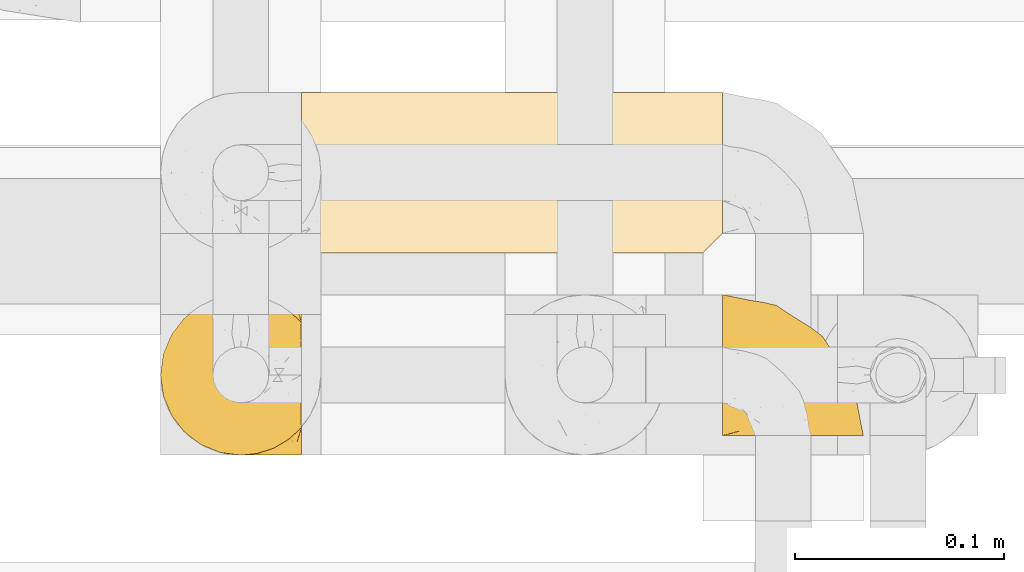
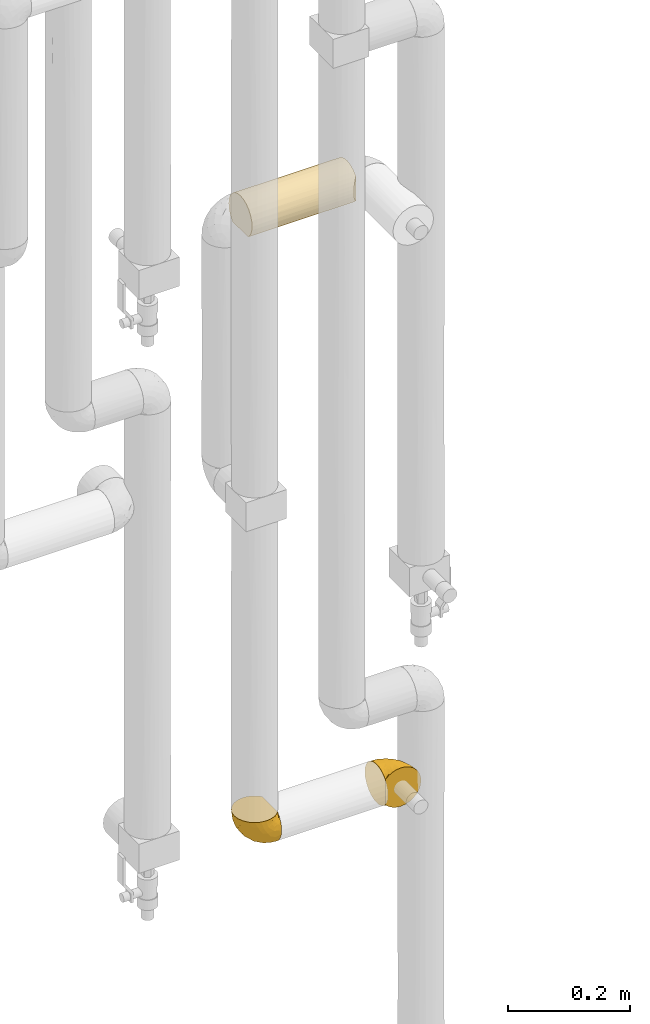
# One storey, part 282 of 827: 3 coverings.
"""IFC2X3 building model written with IfcOpenShell, lengths in millimetres."""

from ifc_helpers import new_model, entity, si_unit, converted_unit, derived_unit, direction, frame, origin, place, context, subcontext, project, spatial, faceted_brep, element, save


model = new_model("IFC2X3")

# Units and contexts
model_context = context("Model", 3, precision=0.01, world=origin(), true_north=direction((6.12303176911189e-17, 1.0)))
body_context = subcontext(model_context, "Body", "Model", "MODEL_VIEW")
ifc_project = project(units=[si_unit("LENGTHUNIT", "METRE", prefix="MILLI"), si_unit("AREAUNIT", "SQUARE_METRE"), si_unit("VOLUMEUNIT", "CUBIC_METRE"), converted_unit("PLANEANGLEUNIT", "DEGREE", entity("IfcRatioMeasure", 0.0174532925199433), si_unit("PLANEANGLEUNIT", "RADIAN"), dimensions=[0, 0, 0, 0, 0, 0, 0]), si_unit("MASSUNIT", "GRAM", prefix="KILO"), derived_unit("MASSDENSITYUNIT", [(si_unit("MASSUNIT", "GRAM", prefix="KILO"), 1), (si_unit("LENGTHUNIT", "METRE"), -3)]), derived_unit("MOMENTOFINERTIAUNIT", [(si_unit("LENGTHUNIT", "METRE"), 4)]), si_unit("TIMEUNIT", "SECOND"), si_unit("FREQUENCYUNIT", "HERTZ"), si_unit("THERMODYNAMICTEMPERATUREUNIT", "DEGREE_CELSIUS"), derived_unit("THERMALTRANSMITTANCEUNIT", [(si_unit("MASSUNIT", "GRAM", prefix="KILO"), 1), (si_unit("THERMODYNAMICTEMPERATUREUNIT", "KELVIN"), -1), (si_unit("TIMEUNIT", "SECOND"), -3)]), derived_unit("VOLUMETRICFLOWRATEUNIT", [(si_unit("LENGTHUNIT", "METRE"), 3), (si_unit("TIMEUNIT", "SECOND"), -1)]), derived_unit("MASSFLOWRATEUNIT", [(si_unit("MASSUNIT", "GRAM", prefix="KILO"), 1), (si_unit("TIMEUNIT", "SECOND"), -1)]), derived_unit("ROTATIONALFREQUENCYUNIT", [(si_unit("TIMEUNIT", "SECOND"), -1)]), si_unit("ELECTRICCURRENTUNIT", "AMPERE"), si_unit("ELECTRICVOLTAGEUNIT", "VOLT"), si_unit("POWERUNIT", "WATT"), si_unit("FORCEUNIT", "NEWTON", prefix="KILO"), si_unit("ILLUMINANCEUNIT", "LUX"), si_unit("LUMINOUSFLUXUNIT", "LUMEN"), si_unit("LUMINOUSINTENSITYUNIT", "CANDELA"), derived_unit("USERDEFINED", [(si_unit("MASSUNIT", "GRAM", prefix="KILO"), -1), (si_unit("LENGTHUNIT", "METRE"), -2), (si_unit("TIMEUNIT", "SECOND"), 3), (si_unit("LUMINOUSFLUXUNIT", "LUMEN"), 1)]), derived_unit("LINEARVELOCITYUNIT", [(si_unit("LENGTHUNIT", "METRE"), 1), (si_unit("TIMEUNIT", "SECOND"), -1)]), si_unit("PRESSUREUNIT", "PASCAL"), derived_unit("USERDEFINED", [(si_unit("LENGTHUNIT", "METRE"), -2), (si_unit("MASSUNIT", "GRAM", prefix="KILO"), 1), (si_unit("TIMEUNIT", "SECOND"), -2)]), derived_unit("LINEARFORCEUNIT", [(si_unit("MASSUNIT", "GRAM", prefix="KILO"), 1), (si_unit("LENGTHUNIT", "METRE"), 1), (si_unit("TIMEUNIT", "SECOND"), -2), (si_unit("LENGTHUNIT", "METRE"), -1)]), derived_unit("PLANARFORCEUNIT", [(si_unit("MASSUNIT", "GRAM", prefix="KILO"), 1), (si_unit("LENGTHUNIT", "METRE"), 1), (si_unit("TIMEUNIT", "SECOND"), -2), (si_unit("LENGTHUNIT", "METRE"), -2)])], contexts=[model_context])

# Site, building, storey
site_placement = place(None, origin())
site = spatial("IfcSite", under=ifc_project, at=site_placement, CompositionType="ELEMENT")
building_placement = place(site_placement, origin())
building = spatial("IfcBuilding", under=site, at=building_placement, CompositionType="ELEMENT")
storey_placement = place(building_placement, frame((0.0, 0.0, 28200.0)))
storey = spatial("IfcBuildingStorey", under=building, at=storey_placement, Name="08", CompositionType="ELEMENT", Elevation=28200.0)

# Coverings
covering_1_placement = place(storey_placement, frame((34787.8, 14884.87, 1019.95)))
element("IfcCovering", 1, at=covering_1_placement, inside=storey, Name=":ADSK_", ObjectType=":ADSK_", PredefinedType="INSULATION", context=body_context, shape_type="Brep", body=[
    faceted_brep([(69.15, 65.47, 68.89), (69.15, 63.27, 68.89), (69.15, 61.53, 68.89), (69.15, 59.57, 68.89), (69.15, 57.6, 68.89), (69.15, 55.63, 68.89), (69.15, 53.67, 68.89), (69.15, 51.7, 68.89), (69.15, 49.73, 68.89), (69.15, 47.54, 68.89), (69.15, 45.34, 68.89), (69.15, 43.15, 68.89), (69.15, 40.96, 68.89), (69.15, 38.76, 68.89), (69.15, 36.57, 68.89), (69.15, 34.37, 68.89), (69.15, 32.18, 68.89), (69.15, 29.98, 68.89), (69.15, 27.79, 68.89), (69.15, 25.6, 68.89), (69.15, 23.4, 68.89), (69.15, 21.21, 68.89), (69.15, 19.01, 68.89), (69.15, 16.82, 68.89), (69.15, 14.62, 68.89), (69.15, 9.12, 62.89), (69.15, 5.0, 55.86), (69.15, 2.46, 48.13), (69.15, 1.6, 40.05), (69.15, 2.56, 31.49), (69.15, 5.41, 23.36), (69.15, 9.99, 16.07), (69.15, 16.08, 9.98), (69.15, 23.37, 5.4), (69.15, 31.49, 2.56), (69.15, 40.05, 1.6), (69.15, 48.61, 2.56), (69.15, 56.73, 5.41), (69.15, 64.02, 9.99), (69.15, 70.11, 16.08), (69.15, 74.69, 23.37), (69.15, 77.53, 31.49), (69.15, 78.5, 40.05), (69.15, 77.63, 48.15), (69.15, 75.08, 55.88), (69.15, 70.97, 62.9), (68.89, 65.47, 69.15), (62.89, 70.97, 69.15), (55.87, 75.09, 69.15), (48.14, 77.63, 69.15), (40.05, 78.5, 69.15), (30.09, 77.19, 69.15), (20.82, 73.34, 69.15), (12.86, 67.23, 69.15), (6.75, 59.27, 69.15), (2.91, 50.0, 69.15), (1.6, 40.05, 69.15), (2.91, 30.09, 69.15), (6.75, 20.82, 69.15), (12.86, 12.86, 69.15), (20.82, 6.75, 69.15), (30.09, 2.91, 69.15), (40.05, 1.6, 69.15), (48.14, 2.46, 69.15), (55.87, 5.0, 69.15), (62.89, 9.12, 69.15), (68.89, 14.62, 69.15), (68.89, 16.82, 69.15), (68.89, 17.8, 69.15), (68.89, 19.39, 69.15), (68.89, 20.98, 69.15), (68.89, 22.57, 69.15), (68.89, 24.16, 69.15), (68.89, 25.75, 69.15), (68.89, 27.33, 69.15), (68.89, 28.92, 69.15), (68.89, 30.51, 69.15), (68.89, 32.1, 69.15), (68.89, 33.69, 69.15), (68.89, 35.28, 69.15), (68.89, 36.87, 69.15), (68.89, 38.46, 69.15), (68.89, 40.05, 69.15), (68.89, 41.63, 69.15), (68.89, 43.22, 69.15), (68.89, 44.81, 69.15), (68.89, 46.4, 69.15), (68.89, 47.99, 69.15), (68.89, 49.58, 69.15), (68.89, 51.17, 69.15), (68.89, 52.76, 69.15), (68.89, 54.72, 69.15), (68.89, 56.69, 69.15), (68.89, 58.88, 69.15), (68.89, 61.08, 69.15), (68.89, 63.27, 69.15), (68.97, 37.77, 68.96), (68.96, 36.07, 68.97), (68.97, 32.96, 68.97), (68.97, 31.36, 68.97), (68.98, 56.52, 68.95), (68.97, 54.96, 68.96), (68.96, 18.75, 68.98), (68.96, 58.07, 68.97), (68.96, 50.37, 68.97), (68.96, 23.36, 68.98), (68.96, 24.95, 68.97), (68.96, 42.43, 68.97), (69.0, 15.97, 68.94), (68.96, 51.96, 68.98), (68.96, 53.47, 68.98), (68.97, 48.63, 68.96), (68.96, 63.93, 68.97), (68.96, 40.93, 68.98), (68.96, 29.72, 68.98), (68.97, 62.4, 68.97), (68.97, 60.92, 68.96), (68.97, 17.31, 68.97), (68.96, 21.74, 68.97), (68.96, 34.56, 68.98), (68.97, 20.18, 68.96), (68.97, 14.62, 68.97), (69.02, 14.62, 68.94), (69.08, 14.62, 68.92), (68.97, 65.47, 68.97), (68.94, 65.47, 69.02), (68.92, 65.47, 69.08), (68.96, 59.5, 68.98), (68.96, 47.1, 68.97), (68.95, 45.61, 68.98), (68.96, 28.18, 68.97), (68.92, 14.62, 69.08), (68.94, 14.62, 69.02), (68.98, 26.61, 68.96), (69.08, 65.47, 68.92), (69.02, 65.47, 68.94), (68.96, 39.32, 68.97), (68.97, 44.12, 68.96), (61.33, 72.26, 67.02), (53.1, 76.57, 63.33), (63.33, 71.77, 64.61), (49.27, 78.5, 49.27), (55.53, 77.9, 51.4), (54.6, 78.5, 43.94), (41.99, 78.5, 61.87), (57.07, 75.52, 61.54), (57.95, 76.13, 57.95), (51.56, 77.81, 56.12), (61.7, 72.4, 65.41), (63.33, 76.56, 53.1), (65.0, 71.77, 63.04), (67.02, 72.25, 61.33), (61.87, 78.5, 41.99), (43.94, 78.5, 54.6), (61.21, 75.75, 56.6), (63.4, 78.5, 41.58), (26.0, 75.57, 61.54), (58.71, 76.34, 28.67), (33.48, 77.64, 58.75), (14.17, 63.45, 46.12), (18.43, 70.55, 55.56), (24.87, 71.02, 42.09), (45.01, 66.15, 17.15), (44.4, 60.51, 12.68), (35.53, 63.72, 20.17), (28.67, 75.57, 52.38), (49.25, 72.61, 23.76), (48.22, 76.83, 34.7), (59.72, 72.61, 20.5), (55.1, 67.24, 14.64), (5.25, 47.19, 49.4), (6.75, 54.76, 52.34), (10.47, 63.45, 58.67), (52.82, 52.75, 5.82), (16.81, 53.89, 30.64), (17.38, 46.73, 26.66), (10.56, 48.67, 37.53), (11.2, 55.34, 41.11), (21.38, 40.05, 21.38), (33.11, 50.46, 13.72), (43.3, 40.05, 6.74), (32.34, 40.05, 14.06), (44.72, 77.74, 41.77), (36.52, 77.66, 51.58), (34.15, 57.43, 16.28), (55.54, 40.05, 4.3), (57.42, 60.51, 8.62), (25.49, 60.1, 25.26), (23.96, 51.88, 21.47), (34.84, 72.59, 33.37), (36.87, 76.05, 41.35), (4.3, 40.05, 55.54), (20.65, 63.95, 35.17), (29.66, 67.24, 29.04), (39.6, 69.62, 24.34), (42.55, 73.6, 29.33), (6.74, 40.05, 43.3), (14.06, 40.05, 32.34), (5.28, 32.72, 49.41), (63.4, 1.6, 41.58), (58.71, 3.75, 28.66), (33.13, 29.63, 13.7), (18.52, 27.18, 27.85), (52.83, 27.35, 5.82), (44.4, 19.59, 12.67), (42.69, 12.86, 19.45), (55.1, 12.86, 14.63), (49.26, 7.49, 23.75), (20.72, 9.54, 48.85), (11.46, 16.64, 54.13), (17.69, 17.48, 37.84), (35.35, 2.33, 55.15), (43.94, 1.6, 54.6), (41.99, 1.6, 61.87), (29.34, 8.17, 37.91), (30.26, 4.3, 50.18), (4.93, 26.94, 57.58), (29.72, 20.75, 20.83), (17.46, 9.54, 59.91), (26.84, 4.52, 57.75), (59.73, 7.49, 20.49), (61.87, 1.6, 41.99), (54.6, 1.6, 43.94), (57.43, 19.59, 8.61), (48.2, 3.27, 34.7), (43.06, 2.45, 42.64), (49.27, 1.6, 49.27), (10.94, 31.21, 36.94), (8.92, 25.33, 45.72), (33.44, 2.29, 62.29), (29.67, 12.86, 29.01), (38.5, 6.89, 31.47), (39.06, 2.23, 49.29), (23.35, 12.43, 37.18), (34.97, 4.1, 43.45), (53.1, 3.53, 63.33), (59.68, 6.88, 67.23), (62.19, 8.16, 66.07), (64.11, 9.02, 65.22), (57.97, 5.0, 61.99), (57.95, 3.96, 57.95), (63.33, 3.52, 53.09), (51.77, 2.4, 56.84), (67.02, 7.83, 61.33), (64.98, 8.32, 63.06), (55.53, 2.19, 51.41), (61.22, 4.34, 56.61)], [[[0, 1, 2, 3, 4, 5, 6, 7, 8, 9, 10, 11, 12, 13, 14, 15, 16, 17, 18, 19, 20, 21, 22, 23, 24, 25, 26, 27, 28, 29, 30, 31, 32, 33, 34, 35, 36, 37, 38, 39, 40, 41, 42, 43, 44, 45]], [[46, 47, 48, 49, 50, 51, 52, 53, 54, 55, 56, 57, 58, 59, 60, 61, 62, 63, 64, 65, 66, 67, 68, 69, 70, 71, 72, 73, 74, 75, 76, 77, 78, 79, 80, 81, 82, 83, 84, 85, 86, 87, 88, 89, 90, 91, 92, 93, 94, 95]], [[96, 97, 14]], [[98, 77, 99]], [[100, 101, 5]], [[69, 68, 102]], [[4, 3, 103]], [[8, 7, 104]], [[4, 103, 100]], [[72, 105, 106]], [[84, 83, 107]], [[89, 88, 104]], [[108, 67, 66]], [[109, 110, 90]], [[111, 9, 8]], [[112, 1, 0]], [[82, 113, 83]], [[109, 7, 6]], [[114, 76, 75]], [[105, 20, 106]], [[104, 111, 8]], [[2, 115, 116]], [[97, 96, 80]], [[67, 108, 117]], [[105, 71, 118]], [[15, 97, 119]], [[102, 120, 69]], [[108, 121, 122, 123, 24]], [[112, 95, 115]], [[1, 115, 2]], [[94, 116, 115]], [[117, 68, 67]], [[22, 117, 23]], [[112, 124, 125, 126, 46]], [[1, 112, 115]], [[70, 120, 118]], [[23, 117, 108]], [[120, 22, 21]], [[120, 21, 118]], [[120, 70, 69]], [[116, 94, 127]], [[128, 86, 129]], [[117, 22, 102]], [[74, 130, 75]], [[99, 17, 16]], [[115, 95, 94]], [[23, 108, 24]], [[108, 66, 131, 132, 121]], [[105, 72, 71]], [[118, 21, 20]], [[71, 70, 118]], [[19, 106, 20]], [[20, 105, 118]], [[19, 133, 106]], [[74, 73, 133]], [[106, 133, 73]], [[99, 114, 17]], [[133, 19, 18]], [[73, 72, 106]], [[95, 112, 46]], [[112, 0, 134, 135, 124]], [[130, 114, 75]], [[99, 76, 114]], [[114, 130, 17]], [[18, 17, 130]], [[78, 77, 98]], [[98, 119, 78]], [[130, 133, 18]], [[133, 130, 74]], [[79, 97, 80]], [[98, 99, 16]], [[98, 16, 15]], [[77, 76, 99]], [[97, 79, 119]], [[136, 96, 13]], [[14, 97, 15]], [[136, 13, 12]], [[81, 80, 96]], [[13, 96, 14]], [[15, 119, 98]], [[119, 79, 78]], [[96, 136, 81]], [[82, 81, 136]], [[113, 107, 83]], [[84, 107, 137]], [[107, 11, 137]], [[113, 12, 107]], [[11, 107, 12]], [[85, 84, 137]], [[137, 11, 10]], [[113, 136, 12]], [[136, 113, 82]], [[109, 89, 104]], [[86, 85, 129]], [[89, 109, 90]], [[111, 87, 128]], [[10, 129, 137]], [[88, 111, 104]], [[9, 111, 128]], [[6, 110, 109]], [[7, 109, 104]], [[110, 91, 90]], [[100, 92, 101]], [[110, 6, 101]], [[91, 110, 101]], [[116, 3, 2]], [[111, 88, 87]], [[127, 103, 3]], [[9, 128, 10]], [[86, 128, 87]], [[128, 129, 10]], [[137, 129, 85]], [[120, 102, 22]], [[117, 102, 68]], [[91, 101, 92]], [[5, 101, 6]], [[93, 92, 103]], [[100, 5, 4]], [[100, 103, 92]], [[127, 93, 103]], [[93, 127, 94]], [[116, 127, 3]], [[126, 138, 47]], [[48, 138, 139]], [[140, 125, 124]], [[141, 142, 143]], [[144, 49, 139]], [[145, 140, 146]], [[48, 139, 49]], [[139, 145, 147]], [[144, 50, 49]], [[126, 125, 148]], [[44, 43, 149]], [[150, 146, 140]], [[148, 140, 145]], [[151, 150, 135]], [[151, 44, 149]], [[0, 45, 134]], [[43, 152, 149]], [[124, 150, 140]], [[141, 147, 142]], [[44, 151, 45]], [[45, 151, 134]], [[47, 46, 126]], [[139, 153, 144]], [[138, 48, 47]], [[125, 140, 148]], [[135, 134, 151]], [[146, 154, 142]], [[145, 146, 147]], [[148, 139, 138]], [[147, 141, 153]], [[147, 146, 142]], [[139, 147, 153]], [[139, 148, 145]], [[148, 138, 126]], [[154, 146, 150]], [[149, 143, 142]], [[151, 154, 150]], [[149, 142, 154]], [[43, 42, 155, 152]], [[152, 143, 149]], [[151, 149, 154]], [[150, 124, 135]], [[51, 156, 52]], [[155, 41, 157]], [[50, 144, 158]], [[159, 160, 161]], [[162, 163, 164]], [[158, 165, 156]], [[157, 166, 167]], [[166, 168, 169]], [[170, 55, 171]], [[161, 160, 165]], [[172, 54, 53]], [[160, 53, 52]], [[173, 37, 36]], [[54, 172, 171]], [[174, 175, 176]], [[170, 177, 176]], [[167, 143, 157]], [[178, 179, 180, 181]], [[157, 41, 40]], [[141, 182, 183]], [[160, 52, 156]], [[173, 179, 184]], [[38, 169, 39]], [[173, 36, 185]], [[155, 42, 41]], [[38, 37, 186]], [[162, 169, 163]], [[187, 184, 188]], [[180, 173, 185]], [[40, 168, 157]], [[54, 171, 55]], [[186, 173, 163]], [[157, 143, 152, 155]], [[189, 161, 190]], [[179, 173, 180]], [[39, 168, 40]], [[186, 169, 38]], [[187, 164, 184]], [[144, 183, 158]], [[172, 160, 159]], [[177, 174, 176]], [[55, 170, 191]], [[187, 192, 193]], [[183, 182, 190]], [[166, 194, 195]], [[167, 190, 182]], [[36, 35, 185]], [[173, 186, 37]], [[169, 186, 163]], [[169, 168, 39]], [[157, 168, 166]], [[190, 161, 165]], [[161, 193, 192]], [[183, 165, 158]], [[194, 189, 195]], [[191, 170, 196]], [[191, 56, 55]], [[175, 178, 197]], [[197, 196, 176]], [[170, 176, 196]], [[188, 175, 174]], [[197, 176, 175]], [[177, 170, 171]], [[171, 159, 177]], [[192, 177, 159]], [[187, 188, 174]], [[188, 179, 178]], [[174, 177, 192]], [[164, 187, 193]], [[174, 192, 187]], [[161, 192, 159]], [[194, 164, 193]], [[184, 164, 163]], [[189, 194, 193]], [[162, 166, 169]], [[161, 189, 193]], [[195, 190, 167]], [[173, 184, 163]], [[184, 179, 188]], [[164, 194, 162]], [[166, 162, 194]], [[190, 195, 189]], [[167, 182, 143]], [[167, 166, 195]], [[160, 172, 53]], [[171, 172, 159]], [[51, 50, 158]], [[160, 156, 165]], [[51, 158, 156]], [[183, 144, 153]], [[141, 183, 153]], [[190, 165, 183]], [[178, 175, 188]], [[143, 182, 141]], [[198, 191, 196]], [[29, 199, 200]], [[178, 201, 202]], [[201, 203, 204]], [[205, 206, 207]], [[57, 56, 191]], [[34, 185, 35]], [[208, 209, 210]], [[211, 212, 213]], [[208, 214, 215]], [[216, 209, 58]], [[201, 217, 202]], [[59, 218, 60]], [[60, 218, 219]], [[201, 178, 181, 180]], [[31, 30, 220]], [[201, 180, 203]], [[200, 199, 221, 222]], [[203, 185, 34]], [[33, 203, 34]], [[32, 31, 206]], [[217, 210, 202]], [[58, 209, 59]], [[33, 223, 203]], [[207, 220, 200]], [[204, 223, 206]], [[205, 204, 206]], [[207, 200, 224]], [[200, 222, 224]], [[206, 223, 32]], [[225, 222, 226]], [[220, 206, 31]], [[60, 219, 61]], [[57, 198, 216]], [[227, 202, 228]], [[33, 32, 223]], [[29, 28, 199]], [[30, 29, 200]], [[219, 211, 229]], [[230, 231, 214]], [[231, 207, 224]], [[210, 209, 228]], [[218, 209, 208]], [[226, 232, 225]], [[231, 230, 205]], [[202, 210, 228]], [[233, 230, 214]], [[227, 228, 198]], [[201, 204, 217]], [[211, 232, 212]], [[180, 185, 203]], [[61, 229, 62]], [[203, 223, 204]], [[200, 220, 30]], [[206, 220, 207]], [[225, 231, 224]], [[232, 226, 212]], [[214, 231, 234]], [[197, 227, 196]], [[191, 198, 57]], [[198, 228, 216]], [[202, 197, 178]], [[196, 227, 198]], [[197, 202, 227]], [[209, 216, 228]], [[58, 57, 216]], [[229, 211, 213]], [[215, 211, 219]], [[205, 217, 204]], [[210, 217, 230]], [[62, 229, 213]], [[219, 229, 61]], [[231, 205, 207]], [[217, 205, 230]], [[215, 214, 234]], [[233, 208, 210]], [[209, 218, 59]], [[219, 218, 208]], [[208, 215, 219]], [[232, 215, 234]], [[215, 232, 211]], [[232, 234, 225]], [[231, 225, 234]], [[222, 225, 224]], [[208, 233, 214]], [[210, 230, 233]], [[63, 213, 235]], [[213, 212, 235]], [[213, 63, 62]], [[236, 235, 237]], [[237, 132, 131]], [[235, 236, 64]], [[238, 239, 240]], [[63, 235, 64]], [[131, 66, 65]], [[236, 131, 65]], [[241, 221, 27]], [[236, 65, 64]], [[238, 121, 132]], [[26, 241, 27]], [[240, 239, 242]], [[25, 123, 243]], [[27, 221, 199, 28]], [[243, 122, 244]], [[226, 245, 242]], [[240, 242, 245]], [[121, 238, 244]], [[25, 24, 123]], [[132, 237, 238]], [[243, 26, 25]], [[131, 236, 237]], [[239, 238, 237]], [[244, 238, 240]], [[246, 240, 245]], [[246, 243, 244]], [[237, 235, 239]], [[242, 235, 212]], [[235, 242, 239]], [[222, 245, 226]], [[242, 212, 226]], [[222, 241, 245]], [[240, 246, 244]], [[245, 241, 246]], [[243, 246, 241]], [[241, 222, 221]], [[26, 243, 241]], [[122, 243, 123]], [[122, 121, 244]]]),
])
covering_2_placement = place(storey_placement, frame((35057.15, 14894.22, 1019.95)))
element("IfcCovering", 2, at=covering_2_placement, inside=storey, Name=":ADSK_", ObjectType=":ADSK_", PredefinedType="INSULATION", context=body_context, shape_type="Brep", body=[
    faceted_brep([(47.38, 1.6, 5.41), (54.67, 1.6, 9.99), (60.76, 1.6, 16.08), (65.34, 1.6, 23.37), (68.18, 1.6, 31.49), (69.15, 1.6, 40.05), (68.18, 1.6, 48.61), (65.33, 1.6, 56.73), (60.75, 1.6, 64.02), (54.66, 1.6, 70.11), (47.37, 1.6, 74.69), (39.25, 1.6, 77.53), (30.7, 1.6, 78.5), (22.59, 1.6, 77.63), (14.86, 1.6, 75.08), (7.84, 1.6, 70.97), (1.85, 1.6, 65.47), (1.85, 1.6, 63.27), (1.85, 1.6, 61.53), (1.85, 1.6, 59.57), (1.85, 1.6, 57.6), (1.85, 1.6, 55.63), (1.85, 1.6, 53.67), (1.85, 1.6, 51.7), (1.85, 1.6, 49.73), (1.85, 1.6, 47.54), (1.85, 1.6, 45.34), (1.85, 1.6, 43.15), (1.85, 1.6, 40.96), (1.85, 1.6, 38.76), (1.85, 1.6, 36.57), (1.85, 1.6, 34.37), (1.85, 1.6, 32.18), (1.85, 1.6, 29.98), (1.85, 1.6, 27.79), (1.85, 1.6, 25.6), (1.85, 1.6, 23.4), (1.85, 1.6, 21.21), (1.85, 1.6, 19.01), (1.85, 1.6, 16.82), (1.85, 1.6, 14.62), (7.85, 1.6, 9.12), (14.88, 1.6, 5.0), (22.61, 1.6, 2.46), (30.7, 1.6, 1.6), (39.26, 1.6, 2.56), (1.6, 1.85, 65.47), (1.6, 7.85, 70.97), (1.6, 14.87, 75.09), (1.6, 22.6, 77.63), (1.6, 30.7, 78.5), (1.6, 40.65, 77.19), (1.6, 49.92, 73.34), (1.6, 57.88, 67.23), (1.6, 63.99, 59.27), (1.6, 67.84, 50.0), (1.6, 69.15, 40.05), (1.6, 67.84, 30.09), (1.6, 63.99, 20.82), (1.6, 57.88, 12.86), (1.6, 49.92, 6.75), (1.6, 40.65, 2.91), (1.6, 30.7, 1.6), (1.6, 22.6, 2.46), (1.6, 14.87, 5.0), (1.6, 7.85, 9.12), (1.6, 1.85, 14.62), (1.6, 1.85, 16.82), (1.6, 1.85, 17.8), (1.6, 1.85, 19.39), (1.6, 1.85, 20.98), (1.6, 1.85, 22.57), (1.6, 1.85, 24.16), (1.6, 1.85, 25.75), (1.6, 1.85, 27.33), (1.6, 1.85, 28.92), (1.6, 1.85, 30.51), (1.6, 1.85, 32.1), (1.6, 1.85, 33.69), (1.6, 1.85, 35.28), (1.6, 1.85, 36.87), (1.6, 1.85, 38.46), (1.6, 1.85, 40.05), (1.6, 1.85, 41.63), (1.6, 1.85, 43.22), (1.6, 1.85, 44.81), (1.6, 1.85, 46.4), (1.6, 1.85, 47.99), (1.6, 1.85, 49.58), (1.6, 1.85, 51.17), (1.6, 1.85, 52.76), (1.6, 1.85, 54.72), (1.6, 1.85, 56.69), (1.6, 1.85, 58.88), (1.6, 1.85, 61.08), (1.6, 1.85, 63.27), (1.78, 1.77, 37.77), (1.77, 1.78, 36.07), (1.78, 1.77, 32.96), (1.77, 1.77, 31.36), (1.79, 1.76, 56.52), (1.78, 1.77, 54.96), (1.76, 1.79, 18.75), (1.77, 1.78, 58.07), (1.77, 1.78, 50.37), (1.76, 1.78, 23.36), (1.77, 1.78, 24.95), (1.77, 1.78, 42.43), (1.8, 1.74, 15.97), (1.76, 1.78, 51.96), (1.77, 1.78, 53.47), (1.78, 1.77, 48.63), (1.77, 1.78, 63.93), (1.77, 1.78, 40.93), (1.76, 1.78, 29.72), (1.77, 1.77, 62.4), (1.78, 1.77, 60.92), (1.77, 1.77, 17.31), (1.77, 1.78, 21.74), (1.77, 1.78, 34.56), (1.78, 1.77, 20.18), (1.77, 1.77, 14.62), (1.8, 1.72, 14.62), (1.82, 1.66, 14.62), (1.77, 1.77, 65.47), (1.72, 1.8, 65.47), (1.66, 1.82, 65.47), (1.76, 1.79, 59.5), (1.77, 1.78, 47.1), (1.76, 1.79, 45.61), (1.77, 1.78, 28.18), (1.66, 1.82, 14.62), (1.72, 1.8, 14.62), (1.78, 1.76, 26.61), (1.82, 1.66, 65.47), (1.8, 1.72, 65.47), (1.77, 1.78, 39.32), (1.78, 1.77, 44.12), (3.72, 9.41, 72.26), (7.41, 17.65, 76.57), (6.13, 7.41, 71.77), (19.34, 15.21, 77.9), (17.64, 7.41, 76.56), (26.8, 16.15, 78.5), (8.87, 28.75, 78.5), (9.2, 13.67, 75.52), (12.79, 12.79, 76.13), (14.62, 19.18, 77.81), (5.33, 9.04, 72.4), (7.7, 5.74, 71.77), (9.41, 3.72, 72.25), (28.75, 8.87, 78.5), (21.47, 21.47, 78.5), (16.15, 26.8, 78.5), (14.14, 9.53, 75.75), (29.16, 7.34, 78.5), (9.2, 44.74, 75.57), (42.07, 12.03, 76.34), (11.99, 37.26, 77.64), (24.62, 56.57, 63.45), (15.19, 52.31, 70.55), (28.65, 45.87, 71.02), (53.59, 25.73, 66.15), (58.06, 26.34, 60.51), (50.57, 35.21, 63.72), (18.36, 42.07, 75.57), (46.98, 21.49, 72.61), (36.04, 22.52, 76.83), (50.24, 11.02, 72.61), (56.1, 15.64, 67.24), (21.34, 65.49, 47.19), (18.4, 63.99, 54.76), (12.07, 60.27, 63.45), (64.92, 17.92, 52.75), (40.1, 53.93, 53.89), (44.08, 53.36, 46.73), (33.21, 60.18, 48.67), (29.63, 59.54, 55.34), (49.36, 49.36, 40.05), (57.02, 37.63, 50.46), (64.0, 27.45, 40.05), (56.68, 38.4, 40.05), (28.97, 26.02, 77.74), (19.16, 34.22, 77.66), (54.46, 36.59, 57.43), (66.44, 15.2, 40.05), (62.12, 13.32, 60.51), (45.49, 45.25, 60.1), (49.27, 46.78, 51.88), (37.37, 35.9, 72.59), (29.39, 33.87, 76.05), (15.2, 66.44, 40.05), (35.57, 50.09, 63.95), (41.7, 41.08, 67.24), (46.4, 31.14, 69.62), (41.41, 28.19, 73.6), (27.45, 64.0, 40.05), (38.4, 56.68, 40.05), (21.33, 65.46, 32.72), (29.16, 7.34, 1.6), (42.08, 12.03, 3.75), (57.04, 37.61, 29.63), (42.89, 52.22, 27.18), (64.92, 17.91, 27.35), (58.07, 26.34, 19.59), (51.29, 28.05, 12.86), (56.11, 15.64, 12.86), (46.99, 21.48, 7.49), (21.89, 50.02, 9.54), (16.62, 59.28, 16.64), (32.9, 53.05, 17.48), (15.6, 35.39, 2.33), (16.15, 26.8, 1.6), (8.87, 28.75, 1.6), (32.83, 41.4, 8.17), (20.56, 40.48, 4.3), (13.16, 65.81, 26.94), (49.91, 41.02, 20.75), (10.83, 53.28, 9.54), (12.99, 43.9, 4.52), (50.25, 11.01, 7.49), (28.75, 8.87, 1.6), (26.8, 16.15, 1.6), (62.13, 13.31, 19.59), (36.04, 22.54, 3.27), (28.1, 27.68, 2.45), (21.47, 21.47, 1.6), (33.8, 59.8, 31.21), (25.02, 61.82, 25.33), (8.45, 37.3, 2.29), (41.73, 41.07, 12.86), (39.27, 32.24, 6.89), (21.46, 31.68, 2.23), (33.56, 47.4, 12.43), (27.29, 35.77, 4.1), (7.41, 17.65, 3.53), (3.51, 11.06, 6.88), (4.68, 8.55, 8.16), (5.52, 6.63, 9.02), (8.75, 12.77, 5.0), (12.79, 12.79, 3.96), (17.65, 7.41, 3.52), (13.9, 18.97, 2.4), (9.42, 3.72, 7.83), (7.68, 5.76, 8.32), (19.33, 15.21, 2.19), (14.13, 9.52, 4.34)], [[[0, 1, 2, 3, 4, 5, 6, 7, 8, 9, 10, 11, 12, 13, 14, 15, 16, 17, 18, 19, 20, 21, 22, 23, 24, 25, 26, 27, 28, 29, 30, 31, 32, 33, 34, 35, 36, 37, 38, 39, 40, 41, 42, 43, 44, 45]], [[46, 47, 48, 49, 50, 51, 52, 53, 54, 55, 56, 57, 58, 59, 60, 61, 62, 63, 64, 65, 66, 67, 68, 69, 70, 71, 72, 73, 74, 75, 76, 77, 78, 79, 80, 81, 82, 83, 84, 85, 86, 87, 88, 89, 90, 91, 92, 93, 94, 95]], [[96, 97, 30]], [[98, 77, 99]], [[100, 101, 21]], [[69, 68, 102]], [[20, 19, 103]], [[24, 23, 104]], [[20, 103, 100]], [[72, 105, 106]], [[84, 83, 107]], [[89, 88, 104]], [[108, 67, 66]], [[109, 110, 90]], [[111, 25, 24]], [[112, 17, 16]], [[82, 113, 83]], [[109, 23, 22]], [[114, 76, 75]], [[105, 36, 106]], [[104, 111, 24]], [[18, 115, 116]], [[97, 96, 80]], [[67, 108, 117]], [[105, 71, 118]], [[31, 97, 119]], [[102, 120, 69]], [[108, 121, 122, 123, 40]], [[112, 95, 115]], [[17, 115, 18]], [[94, 116, 115]], [[117, 68, 67]], [[38, 117, 39]], [[112, 124, 125, 126, 46]], [[17, 112, 115]], [[70, 120, 118]], [[39, 117, 108]], [[120, 38, 37]], [[120, 37, 118]], [[120, 70, 69]], [[116, 94, 127]], [[128, 86, 129]], [[117, 38, 102]], [[74, 130, 75]], [[99, 33, 32]], [[115, 95, 94]], [[39, 108, 40]], [[108, 66, 131, 132, 121]], [[105, 72, 71]], [[118, 37, 36]], [[71, 70, 118]], [[35, 106, 36]], [[36, 105, 118]], [[35, 133, 106]], [[74, 73, 133]], [[106, 133, 73]], [[99, 114, 33]], [[133, 35, 34]], [[73, 72, 106]], [[95, 112, 46]], [[112, 16, 134, 135, 124]], [[130, 114, 75]], [[99, 76, 114]], [[114, 130, 33]], [[34, 33, 130]], [[78, 77, 98]], [[98, 119, 78]], [[130, 133, 34]], [[133, 130, 74]], [[79, 97, 80]], [[98, 99, 32]], [[98, 32, 31]], [[77, 76, 99]], [[97, 79, 119]], [[136, 96, 29]], [[30, 97, 31]], [[136, 29, 28]], [[81, 80, 96]], [[29, 96, 30]], [[31, 119, 98]], [[119, 79, 78]], [[96, 136, 81]], [[82, 81, 136]], [[113, 107, 83]], [[84, 107, 137]], [[107, 27, 137]], [[113, 28, 107]], [[27, 107, 28]], [[85, 84, 137]], [[137, 27, 26]], [[113, 136, 28]], [[136, 113, 82]], [[109, 89, 104]], [[86, 85, 129]], [[89, 109, 90]], [[111, 87, 128]], [[26, 129, 137]], [[88, 111, 104]], [[25, 111, 128]], [[22, 110, 109]], [[23, 109, 104]], [[110, 91, 90]], [[100, 92, 101]], [[110, 22, 101]], [[91, 110, 101]], [[116, 19, 18]], [[111, 88, 87]], [[127, 103, 19]], [[25, 128, 26]], [[86, 128, 87]], [[128, 129, 26]], [[137, 129, 85]], [[120, 102, 38]], [[117, 102, 68]], [[91, 101, 92]], [[21, 101, 22]], [[93, 92, 103]], [[100, 21, 20]], [[100, 103, 92]], [[127, 93, 103]], [[93, 127, 94]], [[116, 127, 19]], [[126, 138, 47]], [[48, 138, 139]], [[140, 125, 124]], [[141, 142, 143]], [[144, 49, 139]], [[145, 140, 146]], [[48, 139, 49]], [[139, 145, 147]], [[144, 50, 49]], [[126, 125, 148]], [[14, 13, 142]], [[149, 146, 140]], [[148, 140, 145]], [[150, 149, 135]], [[150, 14, 142]], [[16, 15, 134]], [[13, 151, 142]], [[124, 149, 140]], [[141, 143, 152]], [[14, 150, 15]], [[15, 150, 134]], [[47, 46, 126]], [[139, 153, 144]], [[138, 48, 47]], [[125, 140, 148]], [[135, 134, 150]], [[146, 154, 141]], [[145, 146, 147]], [[148, 139, 138]], [[147, 152, 153]], [[147, 146, 141]], [[139, 147, 153]], [[139, 148, 145]], [[148, 138, 126]], [[147, 141, 152]], [[146, 149, 154]], [[150, 154, 149]], [[142, 141, 154]], [[13, 12, 155, 151]], [[151, 143, 142]], [[150, 142, 154]], [[149, 124, 135]], [[51, 156, 52]], [[155, 11, 157]], [[50, 144, 158]], [[159, 160, 161]], [[162, 163, 164]], [[158, 165, 156]], [[157, 166, 167]], [[166, 168, 169]], [[170, 55, 171]], [[161, 160, 165]], [[172, 54, 53]], [[160, 53, 52]], [[173, 7, 6]], [[54, 172, 171]], [[174, 175, 176]], [[170, 177, 176]], [[167, 143, 157]], [[178, 179, 180, 181]], [[157, 11, 10]], [[152, 182, 183]], [[160, 52, 156]], [[173, 179, 184]], [[8, 169, 9]], [[173, 6, 185]], [[155, 12, 11]], [[8, 7, 186]], [[162, 169, 163]], [[187, 184, 188]], [[180, 173, 185]], [[10, 168, 157]], [[54, 171, 55]], [[186, 173, 163]], [[157, 143, 151, 155]], [[189, 161, 190]], [[179, 173, 180]], [[9, 168, 10]], [[186, 169, 8]], [[187, 164, 184]], [[144, 183, 158]], [[172, 160, 159]], [[177, 174, 176]], [[55, 170, 191]], [[187, 192, 193]], [[183, 182, 190]], [[166, 194, 195]], [[167, 190, 182]], [[6, 5, 185]], [[173, 186, 7]], [[169, 186, 163]], [[169, 168, 9]], [[157, 168, 166]], [[190, 161, 165]], [[161, 193, 192]], [[183, 165, 158]], [[194, 189, 195]], [[191, 170, 196]], [[191, 56, 55]], [[175, 178, 197]], [[197, 196, 176]], [[170, 176, 196]], [[188, 175, 174]], [[197, 176, 175]], [[177, 170, 171]], [[171, 159, 177]], [[192, 177, 159]], [[187, 188, 174]], [[188, 179, 178]], [[174, 177, 192]], [[164, 187, 193]], [[174, 192, 187]], [[161, 192, 159]], [[194, 164, 193]], [[184, 164, 163]], [[189, 194, 193]], [[162, 166, 169]], [[161, 189, 193]], [[195, 190, 167]], [[173, 184, 163]], [[184, 179, 188]], [[164, 194, 162]], [[166, 162, 194]], [[190, 195, 189]], [[167, 182, 143]], [[167, 166, 195]], [[160, 172, 53]], [[171, 172, 159]], [[51, 50, 158]], [[160, 156, 165]], [[51, 158, 156]], [[183, 144, 153]], [[152, 183, 153]], [[190, 165, 183]], [[178, 175, 188]], [[143, 182, 152]], [[198, 191, 196]], [[45, 199, 200]], [[178, 201, 202]], [[201, 203, 204]], [[205, 206, 207]], [[57, 56, 191]], [[4, 185, 5]], [[208, 209, 210]], [[211, 212, 213]], [[208, 214, 215]], [[216, 209, 58]], [[201, 217, 202]], [[59, 218, 60]], [[60, 218, 219]], [[201, 178, 181, 180]], [[1, 0, 220]], [[201, 180, 203]], [[200, 199, 221, 222]], [[203, 185, 4]], [[3, 203, 4]], [[2, 1, 206]], [[217, 210, 202]], [[58, 209, 59]], [[3, 223, 203]], [[207, 220, 200]], [[204, 223, 206]], [[205, 204, 206]], [[207, 200, 224]], [[200, 222, 224]], [[206, 223, 2]], [[225, 222, 226]], [[220, 206, 1]], [[60, 219, 61]], [[57, 198, 216]], [[227, 202, 228]], [[3, 2, 223]], [[45, 44, 199]], [[0, 45, 200]], [[219, 211, 229]], [[230, 231, 214]], [[231, 207, 224]], [[210, 209, 228]], [[218, 209, 208]], [[226, 232, 225]], [[231, 230, 205]], [[202, 210, 228]], [[233, 230, 214]], [[227, 228, 198]], [[201, 204, 217]], [[211, 232, 212]], [[180, 185, 203]], [[61, 229, 62]], [[203, 223, 204]], [[200, 220, 0]], [[206, 220, 207]], [[225, 231, 224]], [[232, 226, 212]], [[214, 231, 234]], [[197, 227, 196]], [[191, 198, 57]], [[198, 228, 216]], [[202, 197, 178]], [[196, 227, 198]], [[197, 202, 227]], [[209, 216, 228]], [[58, 57, 216]], [[229, 211, 213]], [[215, 211, 219]], [[205, 217, 204]], [[210, 217, 230]], [[62, 229, 213]], [[219, 229, 61]], [[231, 205, 207]], [[217, 205, 230]], [[215, 214, 234]], [[233, 208, 210]], [[209, 218, 59]], [[219, 218, 208]], [[208, 215, 219]], [[232, 215, 234]], [[215, 232, 211]], [[232, 234, 225]], [[231, 225, 234]], [[222, 225, 224]], [[208, 233, 214]], [[210, 230, 233]], [[63, 213, 235]], [[213, 212, 235]], [[213, 63, 62]], [[236, 235, 237]], [[237, 132, 131]], [[235, 236, 64]], [[238, 239, 240]], [[63, 235, 64]], [[131, 66, 65]], [[236, 131, 65]], [[241, 221, 43]], [[236, 65, 64]], [[238, 121, 132]], [[42, 241, 43]], [[240, 239, 242]], [[41, 123, 243]], [[43, 221, 199, 44]], [[243, 122, 244]], [[226, 245, 242]], [[240, 242, 245]], [[121, 238, 244]], [[41, 40, 123]], [[132, 237, 238]], [[243, 42, 41]], [[131, 236, 237]], [[239, 238, 237]], [[244, 238, 240]], [[246, 240, 245]], [[246, 243, 244]], [[237, 235, 239]], [[242, 235, 212]], [[235, 242, 239]], [[222, 245, 226]], [[242, 212, 226]], [[222, 241, 245]], [[240, 246, 244]], [[245, 241, 246]], [[243, 246, 241]], [[241, 222, 221]], [[42, 243, 241]], [[122, 243, 123]], [[122, 121, 244]]]),
])
covering_3_placement = place(storey_placement, frame((34855.35, 14981.91, 2170.0)))
element("IfcCovering", 3, at=covering_3_placement, inside=storey, Name=":ADSK_", ObjectType=":ADSK_", PredefinedType="INSULATION", context=body_context, shape_type="Brep", body=[
    faceted_brep([(203.4, 59.2, 6.74), (203.4, 67.15, 12.84), (203.4, 73.25, 20.8), (203.4, 77.09, 30.06), (203.4, 78.4, 40.0), (203.4, 77.09, 49.93), (203.4, 73.25, 59.2), (203.4, 67.15, 67.15), (203.4, 59.2, 73.25), (203.4, 49.93, 77.09), (203.4, 40.0, 78.4), (203.4, 31.79, 77.51), (203.4, 23.98, 74.9), (203.4, 16.91, 70.68), (203.4, 10.9, 65.05), (203.4, 10.9, 14.94), (203.4, 16.91, 9.31), (203.4, 23.98, 5.09), (203.4, 31.79, 2.48), (203.4, 40.0, 1.6), (203.4, 49.93, 2.9), (1.6, 77.09, 49.93), (1.6, 78.4, 40.0), (1.6, 77.51, 31.79), (1.6, 74.9, 23.98), (1.6, 70.68, 16.91), (1.6, 65.05, 10.9), (1.6, 14.94, 10.9), (1.6, 9.31, 16.91), (1.6, 5.09, 23.98), (1.6, 2.48, 31.79), (1.6, 1.6, 40.0), (1.6, 2.9, 49.93), (1.6, 6.74, 59.2), (1.6, 12.84, 67.15), (1.6, 20.8, 73.25), (1.6, 30.06, 77.09), (1.6, 40.0, 78.4), (1.6, 49.93, 77.09), (1.6, 59.2, 73.25), (1.6, 67.15, 67.15), (1.6, 73.25, 59.2), (194.7, 2.2, 33.21), (196.5, 4.0, 26.63), (199.42, 6.92, 20.48), (194.1, 1.6, 40.0), (5.57, 20.48, 6.92), (8.5, 26.63, 4.0), (10.29, 33.21, 2.2), (10.9, 40.0, 1.6), (10.29, 46.78, 2.2), (8.5, 53.36, 4.0), (5.57, 59.51, 6.92), (196.5, 4.0, 53.36), (194.7, 2.2, 46.78), (199.42, 6.92, 59.51)], [[[0, 1, 2, 3, 4, 5, 6, 7, 8, 9, 10, 11, 12, 13, 14, 15, 16, 17, 18, 19, 20]], [[21, 22, 23, 24, 25, 26, 27, 28, 29, 30, 31, 32, 33, 34, 35, 36, 37, 38, 39, 40, 41]], [[31, 30, 42]], [[30, 29, 43]], [[44, 29, 28]], [[42, 45, 31]], [[44, 43, 29]], [[15, 44, 28]], [[42, 30, 43]], [[28, 27, 15]], [[27, 46, 16]], [[47, 48, 18]], [[46, 47, 17]], [[16, 46, 17]], [[48, 19, 18]], [[18, 17, 47]], [[19, 48, 49]], [[27, 16, 15]], [[50, 51, 20]], [[52, 26, 0]], [[51, 52, 0]], [[49, 50, 19]], [[19, 50, 20]], [[51, 0, 20]], [[26, 1, 0]], [[2, 25, 24]], [[3, 24, 23]], [[4, 23, 22]], [[1, 25, 2]], [[2, 24, 3]], [[23, 4, 3]], [[25, 1, 26]], [[5, 4, 22, 21]], [[6, 5, 21, 41]], [[41, 40, 7, 6]], [[9, 8, 39, 38]], [[10, 9, 38, 37]], [[40, 39, 8, 7]], [[11, 37, 36]], [[12, 36, 35]], [[13, 35, 34]], [[10, 37, 11]], [[11, 36, 12]], [[35, 13, 12]], [[34, 14, 13]], [[53, 33, 32]], [[32, 31, 54]], [[45, 54, 31]], [[55, 14, 33]], [[54, 53, 32]], [[55, 33, 53]], [[33, 14, 34]], [[54, 45, 42, 43, 44, 15, 14, 55, 53]], [[26, 52, 51, 50, 49, 48, 47, 46, 27]]]),
])

save(model, "model.ifc")
